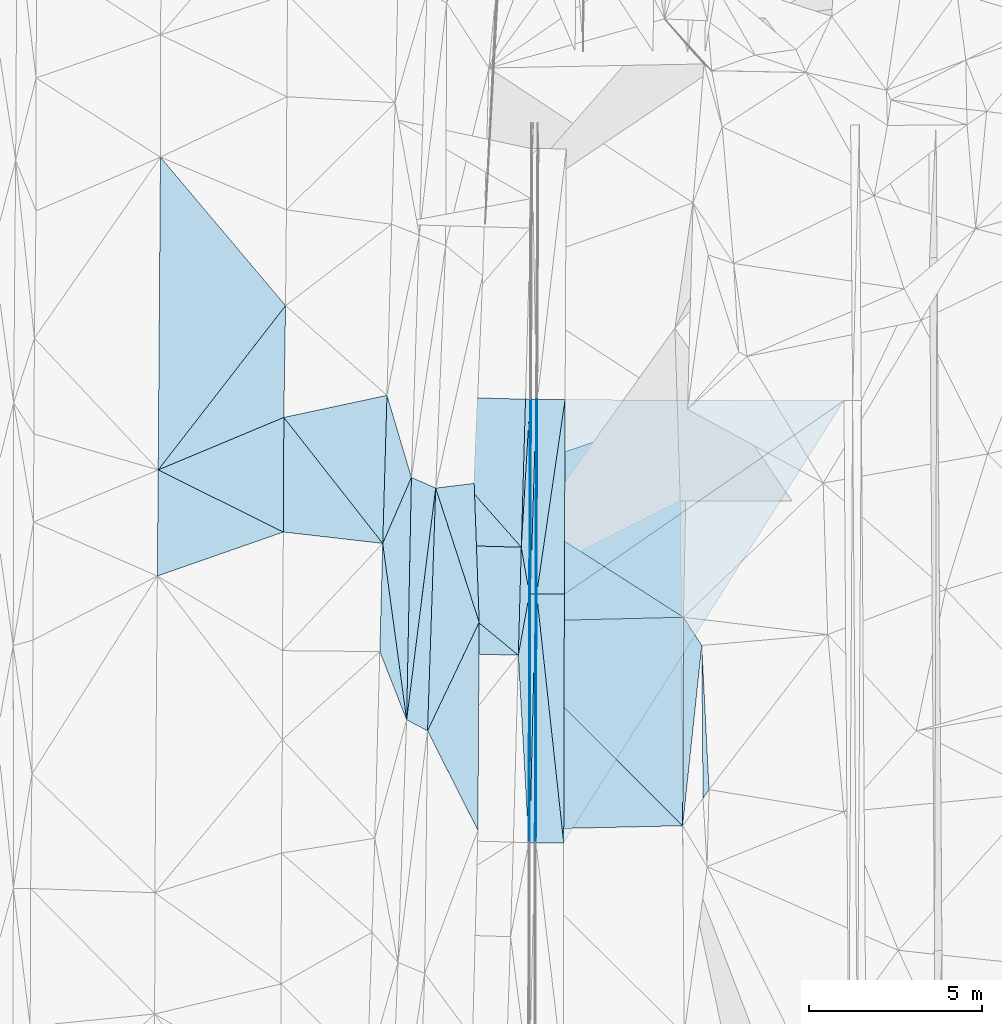
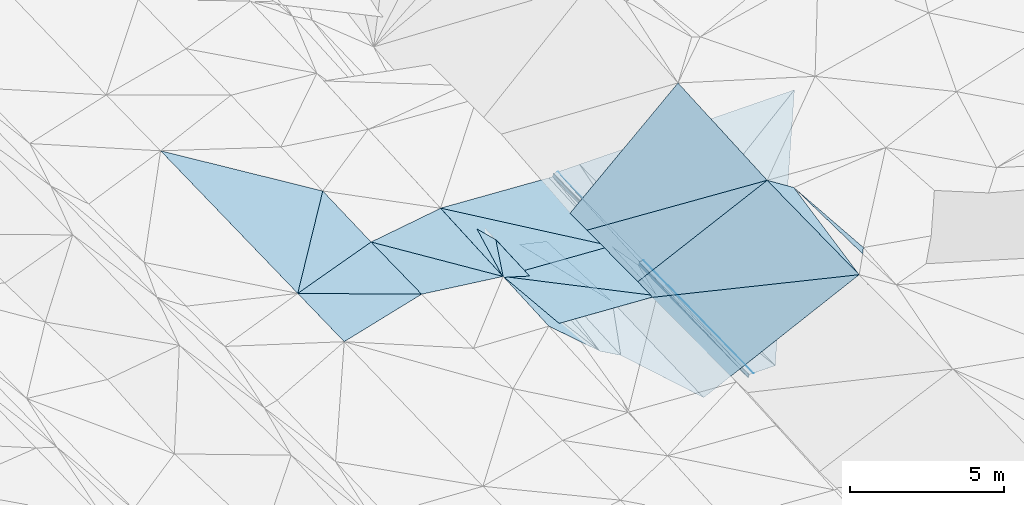
# One storey, part 146 of 275: 46 plates.
"""IFC2X3 building model written with IfcOpenShell, lengths in millimetres."""

from ifc_helpers import new_model, si_unit, frame, origin_with_axes, place, context, subcontext, project, spatial, polyline, outline, extrude, material, type_object, element, save


model = new_model("IFC2X3")

# Units and contexts
model_context = context("Model", 3, precision=1e-05, world=origin_with_axes())
body_context = subcontext(model_context, "Body", "Model", "MODEL_VIEW")
ifc_project = project(units=[si_unit("LENGTHUNIT", "METRE", prefix="MILLI"), si_unit("AREAUNIT", "SQUARE_METRE"), si_unit("VOLUMEUNIT", "CUBIC_METRE"), si_unit("MASSUNIT", "GRAM", prefix="KILO"), si_unit("TIMEUNIT", "SECOND"), si_unit("PLANEANGLEUNIT", "RADIAN"), si_unit("SOLIDANGLEUNIT", "STERADIAN"), si_unit("THERMODYNAMICTEMPERATUREUNIT", "DEGREE_CELSIUS"), si_unit("LUMINOUSINTENSITYUNIT", "LUMEN")], contexts=[model_context])

# Site, building, storey
site_placement = place(None, origin_with_axes())
site = spatial("IfcSite", under=ifc_project, at=site_placement, CompositionType="ELEMENT")
building_placement = place(site_placement, origin_with_axes())
building = spatial("IfcBuilding", under=site, at=building_placement, Name="Undefined", CompositionType="ELEMENT")
storey_placement = place(building_placement, origin_with_axes())
storey = spatial("IfcBuildingStorey", under=building, at=storey_placement, Name="Undefined", CompositionType="ELEMENT", Elevation=0.0)

# Plates
ifc_material = material()
plate_type_1 = type_object("IfcPlateType", PredefinedType="NOTDEFINED")
plate_1_placement = place(storey_placement, frame((-57823.9008921729, 104611.609112402, 43082.6182722905), z_axis=(0.0286392993893599, 0.0163561515630062, -0.999455985442348), x_axis=(0.0594025380463845, 0.9980711664855, 0.0180356620039886)))
element("IfcPlate", 1, at=plate_1_placement, inside=storey, type_object=plate_type_1, material=ifc_material, Name="00_PR", context=body_context, shape_type="SweptSolid", body=[
    extrude(outline(polyline([(0.0, 0.0), (4276.13916015625, -1.90993887372315e-08), (-1334.20239257813, 313.091430664063), (0.0, 0.0)])), frame((-8.85201319254618e-08, 2.18876761149539e-07, -0.5000001331573), z_axis=(0.0, 0.0, 1.0), x_axis=(1.0, 0.0, 0.0)), (0.0, 0.0, 1.0), 1.0),
])
plate_type_2 = type_object("IfcPlateType", PredefinedType="NOTDEFINED")
plate_2_placement = place(storey_placement, frame((-61700.3286359968, 108995.300084847, 43283.7523294641), z_axis=(-0.0315199465246086, 0.0179797566731114, -0.999341393779454), x_axis=(0.999095281886142, -0.0279929429634776, -0.0320158219805999)))
element("IfcPlate", 2, at=plate_2_placement, inside=storey, type_object=plate_type_2, material=ifc_material, Name="00_PR", context=body_context, shape_type="SweptSolid", body=[
    extrude(outline(polyline([(0.0, 0.0), (4002.05249023438, -6.22821971774101e-09), (4002.04248046875, 4274.02734375), (0.0, 0.0)])), frame((-8.85201319254618e-08, 2.18876761149539e-07, -0.5000001331573), z_axis=(0.0, 0.0, 1.0), x_axis=(1.0, 0.0, 0.0)), (0.0, 0.0, 1.0), 1.0),
])
plate_3_placement = place(storey_placement, frame((-57823.9308204421, 104611.610062335, 43082.6183267539), z_axis=(-0.031212602182097, 0.0182517517983424, -0.999346109724411), x_axis=(-0.999123977641245, 0.027314827964167, 0.0317045339915962)))
element("IfcPlate", 3, at=plate_3_placement, inside=storey, type_object=plate_type_2, material=ifc_material, Name="00_PR", context=body_context, shape_type="SweptSolid", body=[
    extrude(outline(polyline([(0.0, 0.0), (4002.01440429688, 6.28642737865448e-09), (3999.11840820313, 4276.76318359375), (0.0, 0.0)])), frame((-8.85201319254618e-08, 2.18876761149539e-07, -0.5000001331573), z_axis=(0.0, 0.0, 1.0), x_axis=(1.0, 0.0, 0.0)), (0.0, 0.0, 1.0), 1.0),
])
plate_type_3 = type_object("IfcPlateType", PredefinedType="NOTDEFINED")
plate_4_placement = place(storey_placement, frame((-61822.4393750529, 104720.924442803, 43209.500328325), z_axis=(-0.0312097734749768, 0.018353166415255, -0.999344340716539), x_axis=(0.999123977642084, -0.0273148279576798, -0.0317045339707643)))
element("IfcPlate", 4, at=plate_4_placement, inside=storey, type_object=plate_type_3, material=ifc_material, Name="00_PR", context=body_context, shape_type="SweptSolid", body=[
    extrude(outline(polyline([(0.0, 0.0), (4002.01440429688, 6.28642737865448e-09), (4003.7431640625, 3119.8994140625), (0.0, 0.0)])), frame((-8.85201319254618e-08, 2.18876761149539e-07, -0.5000001331573), z_axis=(0.0, 0.0, 1.0), x_axis=(1.0, 0.0, 0.0)), (0.0, 0.0, 1.0), 1.0),
])
plate_type_4 = type_object("IfcPlateType", PredefinedType="NOTDEFINED")
plate_5_placement = place(storey_placement, frame((-57909.1824641043, 101493.353414711, 43028.0133275653), z_axis=(-0.031046677135083, 0.0185509911334406, -0.999345768273843), x_axis=(-0.99914793329059, 0.0266263739699584, 0.0315347999891217)))
element("IfcPlate", 5, at=plate_5_placement, inside=storey, type_object=plate_type_4, material=ifc_material, Name="00_PR", context=body_context, shape_type="SweptSolid", body=[
    extrude(outline(polyline([(0.0, 0.0), (4001.99145507813, -5.77711034566164e-09), (4001.58422851563, 3122.66821289063), (0.0, 0.0)])), frame((-8.85201319254618e-08, 2.18876761149539e-07, -0.5000001331573), z_axis=(0.0, 0.0, 1.0), x_axis=(1.0, 0.0, 0.0)), (0.0, 0.0, 1.0), 1.0),
])
plate_type_5 = type_object("IfcPlateType", PredefinedType="NOTDEFINED")
plate_6_placement = place(storey_placement, frame((-57539.4264627461, 108877.337550422, 43280.0837362747), z_axis=(0.970144674503121, 0.000393049729116274, -0.242526608942491), x_axis=(-0.00371188600319583, -0.9998574751376, -0.0164697089762896)))
element("IfcPlate", 6, at=plate_6_placement, inside=storey, type_object=plate_type_5, material=ifc_material, Name="00_PR", context=body_context, shape_type="SweptSolid", body=[
    extrude(outline(polyline([(0.0, 0.0), (5616.76513671875, -1.08411768451333e-08), (5619.00341796875, 123.672706604004), (0.0, 0.0)])), frame((-8.85201319254618e-08, 2.18876761149539e-07, -0.5000001331573), z_axis=(0.0, 0.0, 1.0), x_axis=(1.0, 0.0, 0.0)), (0.0, 0.0, 1.0), 1.0),
])
plate_7_placement = place(storey_placement, frame((-57560.2765250611, 103261.373318993, 43187.5787186943), z_axis=(0.9701348129279, 0.00146785184983346, -0.242561930558561), x_axis=(-0.00264251999267643, -0.999858398584357, -0.0166192619695818)))
element("IfcPlate", 7, at=plate_7_placement, inside=storey, type_object=plate_type_5, material=ifc_material, Name="00_PR", context=body_context, shape_type="SweptSolid", body=[
    extrude(outline(polyline([(0.0, 0.0), (7180.59619140625, -1.12595444079489e-08), (7177.50830078125, 123.675369262695), (0.0, 0.0)])), frame((-8.85201319254618e-08, 2.18876761149539e-07, -0.5000001331573), z_axis=(0.0, 0.0, 1.0), x_axis=(1.0, 0.0, 0.0)), (0.0, 0.0, 1.0), 1.0),
])
plate_8_placement = place(storey_placement, frame((-57569.4166294153, 108879.492210397, 43160.1197385955), z_axis=(0.970145667403756, 0.000392890402904316, -0.242522637407009), x_axis=(0.242492487917739, -0.0174220049627916, 0.969996838678633)))
element("IfcPlate", 8, at=plate_8_placement, inside=storey, type_object=plate_type_5, material=ifc_material, Name="00_PR", context=body_context, shape_type="SweptSolid", body=[
    extrude(outline(polyline([(0.0, 0.0), (123.674629211426, 3.05590219795704e-10), (3.05898642539978, 5619.0703125), (0.0, 0.0)])), frame((-8.85201319254618e-08, 2.18876761149539e-07, -0.5000001331573), z_axis=(0.0, 0.0, 1.0), x_axis=(1.0, 0.0, 0.0)), (0.0, 0.0, 1.0), 1.0),
])
plate_9_placement = place(storey_placement, frame((-57590.2752770446, 103261.22264558, 43067.5787365894), z_axis=(0.970143388926868, 0.00146664967193269, -0.242527635250566), x_axis=(0.242525982975342, 0.00121810203125965, 0.970144145892396)))
element("IfcPlate", 9, at=plate_9_placement, inside=storey, type_object=plate_type_5, material=ifc_material, Name="00_PR", context=body_context, shape_type="SweptSolid", body=[
    extrude(outline(polyline([(0.0, 0.0), (123.69295501709, -7.27595761418343e-11), (-129.022125244141, 7174.1240234375), (0.0, 0.0)])), frame((-8.85201319254618e-08, 2.18876761149539e-07, -0.5000001331573), z_axis=(0.0, 0.0, 1.0), x_axis=(1.0, 0.0, 0.0)), (0.0, 0.0, 1.0), 1.0),
])
plate_type_6 = type_object("IfcPlateType", PredefinedType="NOTDEFINED")
plate_10_placement = place(storey_placement, frame((-57389.91242758, 108876.548700005, 43279.7050679046), z_axis=(8.74944481570353e-05, 0.0164692326707658, -0.999864369162117), x_axis=(-0.030408163980564, -0.999401956745784, -0.016464276966472)))
element("IfcPlate", 10, at=plate_10_placement, inside=storey, type_object=plate_type_6, material=ifc_material, Name="00_PR", context=body_context, shape_type="SweptSolid", body=[
    extrude(outline(polyline([(0.0, 0.0), (5618.52783203125, -8.65838956087828e-10), (3.76478433609009, 149.95393371582), (0.0, 0.0)])), frame((-8.85201319254618e-08, 2.18876761149539e-07, -0.5000001331573), z_axis=(0.0, 0.0, 1.0), x_axis=(1.0, 0.0, 0.0)), (0.0, 0.0, 1.0), 1.0),
])
plate_11_placement = place(storey_placement, frame((-57410.7617565643, 103260.646649343, 43187.2000696347), z_axis=(8.13458011182441e-05, 0.0166183795622564, -0.999861901886248), x_axis=(-0.0235278679924046, -0.999585093013532, -0.0166156929696005)))
element("IfcPlate", 11, at=plate_11_placement, inside=storey, type_object=plate_type_6, material=ifc_material, Name="00_PR", context=body_context, shape_type="SweptSolid", body=[
    extrude(outline(polyline([(0.0, 0.0), (7181.82470703125, 5.07789081893861e-08), (2.79523730278015, 149.975540161133), (0.0, 0.0)])), frame((-8.85201319254618e-08, 2.18876761149539e-07, -0.5000001331573), z_axis=(0.0, 0.0, 1.0), x_axis=(1.0, 0.0, 0.0)), (0.0, 0.0, 1.0), 1.0),
])
plate_12_placement = place(storey_placement, frame((-57560.7615532497, 103261.380817629, 43187.2000701747), z_axis=(8.06177093431787e-05, 0.0164694418593857, -0.999864366294562), x_axis=(0.0304081639715633, 0.99940195674603, 0.0164642769682023)))
element("IfcPlate", 12, at=plate_12_placement, inside=storey, type_object=plate_type_6, material=ifc_material, Name="00_PR", context=body_context, shape_type="SweptSolid", body=[
    extrude(outline(polyline([(0.0, 0.0), (5618.52783203125, -8.65838956087828e-10), (3.82741451263428, 149.952758789063), (0.0, 0.0)])), frame((-8.85201319254618e-08, 2.18876761149539e-07, -0.5000001331573), z_axis=(0.0, 0.0, 1.0), x_axis=(1.0, 0.0, 0.0)), (0.0, 0.0, 1.0), 1.0),
])
plate_13_placement = place(storey_placement, frame((-57579.7348068498, 96081.8015104293, 43067.8690714004), z_axis=(5.05940772002517e-05, 0.0166191032195452, -0.999861891887283), x_axis=(0.0235278679692896, 0.999585093014065, 0.0166156929702854)))
element("IfcPlate", 13, at=plate_13_placement, inside=storey, type_object=plate_type_6, material=ifc_material, Name="00_PR", context=body_context, shape_type="SweptSolid", body=[
    extrude(outline(polyline([(0.0, 0.0), (7181.82470703125, 5.07789081893861e-08), (3.07271218299866, 149.96875), (0.0, 0.0)])), frame((-8.85201319254618e-08, 2.18876761149539e-07, -0.5000001331573), z_axis=(0.0, 0.0, 1.0), x_axis=(1.0, 0.0, 0.0)), (0.0, 0.0, 1.0), 1.0),
])
plate_type_7 = type_object("IfcPlateType", PredefinedType="NOTDEFINED")
plate_14_placement = place(storey_placement, frame((-57359.9029055833, 108876.423056699, 43280.3051671508), z_axis=(0.0200622307838885, 0.0163920484379525, -0.999664347490687), x_axis=(-0.00371188600319583, -0.9998574751376, -0.0164697089762896)))
element("IfcPlate", 14, at=plate_14_placement, inside=storey, type_object=plate_type_7, material=ifc_material, Name="00_PR", context=body_context, shape_type="SweptSolid", body=[
    extrude(outline(polyline([(0.0, 0.0), (5616.6748046875, -1.7018464859575e-08), (-0.00435296120122075, 30.0057964324951), (0.0, 0.0)])), frame((-8.85201319254618e-08, 2.18876761149539e-07, -0.5000001331573), z_axis=(0.0, 0.0, 1.0), x_axis=(1.0, 0.0, 0.0)), (0.0, 0.0, 1.0), 1.0),
])
plate_15_placement = place(storey_placement, frame((-57380.7513738621, 103260.548735517, 43187.8001685812), z_axis=(0.0200470137815082, 0.0165630126239896, -0.999661834747762), x_axis=(-0.00264251999267643, -0.999858398584357, -0.0166192619695818)))
element("IfcPlate", 15, at=plate_15_placement, inside=storey, type_object=plate_type_7, material=ifc_material, Name="00_PR", context=body_context, shape_type="SweptSolid", body=[
    extrude(outline(polyline([(0.0, 0.0), (7180.28271484375, 1.65673554874957e-08), (-0.0086272107437253, 30.0065593719482), (0.0, 0.0)])), frame((-8.85201319254618e-08, 2.18876761149539e-07, -0.5000001331573), z_axis=(0.0, 0.0, 1.0), x_axis=(1.0, 0.0, 0.0)), (0.0, 0.0, 1.0), 1.0),
])
plate_16_placement = place(storey_placement, frame((-57410.751778097, 103260.646536081, 43187.2001698732), z_axis=(0.0200465116787781, 0.0163920272637285, -0.999664663180458), x_axis=(0.00371188599324788, 0.999857475137618, 0.016469708977407)))
element("IfcPlate", 16, at=plate_16_placement, inside=storey, type_object=plate_type_7, material=ifc_material, Name="00_PR", context=body_context, shape_type="SweptSolid", body=[
    extrude(outline(polyline([(0.0, 0.0), (5616.70263671875, -3.97922121919692e-08), (0.0233685877174139, 30.0065517425537), (0.0, 0.0)])), frame((-8.85201319254618e-08, 2.18876761149539e-07, -0.5000001331573), z_axis=(0.0, 0.0, 1.0), x_axis=(1.0, 0.0, 0.0)), (0.0, 0.0, 1.0), 1.0),
])
plate_17_placement = place(storey_placement, frame((-57429.7252913609, 96081.3448377906, 43067.8691710515), z_axis=(0.0200270951198568, 0.0165630718894112, -0.999662233012054), x_axis=(0.00264251997853649, 0.999858398584354, 0.0166192619720087)))
element("IfcPlate", 17, at=plate_17_placement, inside=storey, type_object=plate_type_7, material=ifc_material, Name="00_PR", context=body_context, shape_type="SweptSolid", body=[
    extrude(outline(polyline([(0.0, 0.0), (7180.318359375, 7.71251507103443e-09), (0.0272062122821808, 30.0059127807617), (0.0, 0.0)])), frame((-8.85201319254618e-08, 2.18876761149539e-07, -0.5000001331573), z_axis=(0.0, 0.0, 1.0), x_axis=(1.0, 0.0, 0.0)), (0.0, 0.0, 1.0), 1.0),
])
plate_type_8 = type_object("IfcPlateType", PredefinedType="NOTDEFINED")
plate_18_placement = place(storey_placement, frame((-57569.8858779446, 108879.50010041, 43159.7413161751), z_axis=(0.031644168475463, 0.0161757251763265, -0.99936829673375), x_axis=(-0.0594025380413828, -0.998071166485802, -0.0180356620037383)))
element("IfcPlate", 18, at=plate_18_placement, inside=storey, type_object=plate_type_8, material=ifc_material, Name="00_PR", context=body_context, shape_type="SweptSolid", body=[
    extrude(outline(polyline([(0.0, 0.0), (4276.13916015625, -1.90993887372315e-08), (4.15157032012939, 132.032211303711), (0.0, 0.0)])), frame((-8.85201319254618e-08, 2.18876761149539e-07, -0.5000001331573), z_axis=(0.0, 0.0, 1.0), x_axis=(1.0, 0.0, 0.0)), (0.0, 0.0, 1.0), 1.0),
])
plate_type_9 = type_object("IfcPlateType", PredefinedType="NOTDEFINED")
plate_19_placement = place(storey_placement, frame((-57590.7451207599, 103261.230245587, 43067.2003017855), z_axis=(0.0304511385856356, 0.0166683116903831, -0.999397266128055), x_axis=(-0.177212526972437, -0.983930915753807, -0.0218099359907035)))
element("IfcPlate", 19, at=plate_19_placement, inside=storey, type_object=plate_type_9, material=ifc_material, Name="00_PR", context=body_context, shape_type="SweptSolid", body=[
    extrude(outline(polyline([(0.0, 0.0), (1796.74987792969, -6.76664058119059e-09), (-1287.69799804688, 468.995025634766), (0.0, 0.0)])), frame((-8.85201319254618e-08, 2.18876761149539e-07, -0.5000001331573), z_axis=(0.0, 0.0, 1.0), x_axis=(1.0, 0.0, 0.0)), (0.0, 0.0, 1.0), 1.0),
])
plate_type_10 = type_object("IfcPlateType", PredefinedType="NOTDEFINED")
plate_20_placement = place(storey_placement, frame((-57909.1513230331, 101493.352406836, 43028.0133127853), z_axis=(0.0312267034950166, 0.0165281483901754, -0.999375661750689), x_axis=(0.177212526968748, 0.983930915754403, 0.0218099359937816)))
element("IfcPlate", 20, at=plate_20_placement, inside=storey, type_object=plate_type_10, material=ifc_material, Name="00_PR", context=body_context, shape_type="SweptSolid", body=[
    extrude(outline(polyline([(0.0, 0.0), (1796.74987792969, -6.76664058119059e-09), (-5268.19580078125, 1253.49353027344), (0.0, 0.0)])), frame((-8.85201319254618e-08, 2.18876761149539e-07, -0.5000001331573), z_axis=(0.0, 0.0, 1.0), x_axis=(1.0, 0.0, 0.0)), (0.0, 0.0, 1.0), 1.0),
])
plate_type_11 = type_object("IfcPlateType", PredefinedType="NOTDEFINED")
plate_21_placement = place(storey_placement, frame((-56559.9094753957, 108873.077554814, 43296.3051674812), z_axis=(0.0200465595605787, 0.0163943123081851, -0.999664624748583), x_axis=(-0.00371193902418557, -0.999857438666623, -0.0164719109911862)))
element("IfcPlate", 21, at=plate_21_placement, inside=storey, type_object=plate_type_11, material=ifc_material, Name="00_PR", context=body_context, shape_type="SweptSolid", body=[
    extrude(outline(polyline([(0.0, 0.0), (5615.923828125, 1.74331944435835e-08), (5616.56298828125, 800.159851074219), (0.0, 0.0)])), frame((-8.85201319254618e-08, 2.18876761149539e-07, -0.5000001331573), z_axis=(0.0, 0.0, 1.0), x_axis=(1.0, 0.0, 0.0)), (0.0, 0.0, 1.0), 1.0),
])
plate_22_placement = place(storey_placement, frame((-56580.7554528384, 103257.954424099, 43203.8001693149), z_axis=(0.0200470572782075, 0.0165652372355342, -0.999661797014278), x_axis=(-0.0026425120256765, -0.999858361619525, -0.0166214869886238)))
element("IfcPlate", 22, at=plate_22_placement, inside=storey, type_object=plate_type_11, material=ifc_material, Name="00_PR", context=body_context, shape_type="SweptSolid", body=[
    extrude(outline(polyline([(0.0, 0.0), (7179.32177734375, -2.27446435019374e-08), (-0.213999018073082, 800.160095214844), (0.0, 0.0)])), frame((-8.85201319254618e-08, 2.18876761149539e-07, -0.5000001331573), z_axis=(0.0, 0.0, 1.0), x_axis=(1.0, 0.0, 0.0)), (0.0, 0.0, 1.0), 1.0),
])
plate_23_placement = place(storey_placement, frame((-57380.7513665701, 103260.5486506, 43187.8001674589), z_axis=(0.0200622307838885, 0.0163920484379525, -0.999664347490687), x_axis=(0.00371188599324788, 0.999857475137618, 0.016469708977407)))
element("IfcPlate", 23, at=plate_23_placement, inside=storey, type_object=plate_type_11, material=ifc_material, Name="00_PR", context=body_context, shape_type="SweptSolid", body=[
    extrude(outline(polyline([(0.0, 0.0), (5616.6748046875, -1.7018464859575e-08), (5616.56298828125, 800.160400390625), (0.0, 0.0)])), frame((-8.85201319254618e-08, 2.18876761149539e-07, -0.5000001331573), z_axis=(0.0, 0.0, 1.0), x_axis=(1.0, 0.0, 0.0)), (0.0, 0.0, 1.0), 1.0),
])
plate_24_placement = place(storey_placement, frame((-57399.7254284312, 96081.2828046263, 43068.4691689635), z_axis=(0.0200270951198568, 0.0165630718894112, -0.999662233012054), x_axis=(0.00264251997853649, 0.999858398584354, 0.0166192619720087)))
element("IfcPlate", 24, at=plate_24_placement, inside=storey, type_object=plate_type_11, material=ifc_material, Name="00_PR", context=body_context, shape_type="SweptSolid", body=[
    extrude(outline(polyline([(0.0, 0.0), (7180.28271484375, 1.65673554874957e-08), (0.746965527534485, 800.159790039063), (0.0, 0.0)])), frame((-8.85201319254618e-08, 2.18876761149539e-07, -0.5000001331573), z_axis=(0.0, 0.0, 1.0), x_axis=(1.0, 0.0, 0.0)), (0.0, 0.0, 1.0), 1.0),
])
plate_type_12 = type_object("IfcPlateType", PredefinedType="NOTDEFINED")
plate_25_placement = place(storey_placement, frame((-56580.7554443777, 103257.954339471, 43203.800168191), z_axis=(0.0200619225218566, 0.0163942502081395, -0.999664317571073), x_axis=(0.00371193903121715, 0.999857438666677, 0.0164719109863101)))
element("IfcPlate", 25, at=plate_25_placement, inside=storey, type_object=plate_type_12, material=ifc_material, Name="00_PR", context=body_context, shape_type="SweptSolid", body=[
    extrude(outline(polyline([(0.0, 0.0), (5615.923828125, 1.74331944435835e-08), (5614.79833984375, 8049.54833984375), (0.0, 0.0)])), frame((-8.85201319254618e-08, 2.18876761149539e-07, -0.5000001331573), z_axis=(0.0, 0.0, 1.0), x_axis=(1.0, 0.0, 0.0)), (0.0, 0.0, 1.0), 1.0),
])
plate_type_13 = type_object("IfcPlateType", PredefinedType="NOTDEFINED")
plate_26_placement = place(storey_placement, frame((-56599.7269503277, 96079.6496068809, 43084.4691683066), z_axis=(0.0199434164080744, 0.0165655455214153, -0.999663864928383), x_axis=(0.00264251202433771, 0.99985836161956, 0.0166214869867599)))
element("IfcPlate", 26, at=plate_26_placement, inside=storey, type_object=plate_type_13, material=ifc_material, Name="00_PR", context=body_context, shape_type="SweptSolid", body=[
    extrude(outline(polyline([(0.0, 0.0), (7179.32177734375, -2.27446435019374e-08), (12785.5341796875, 8055.5302734375), (0.0, 0.0)])), frame((-8.85201319254618e-08, 2.18876761149539e-07, -0.5000001331573), z_axis=(0.0, 0.0, 1.0), x_axis=(1.0, 0.0, 0.0)), (0.0, 0.0, 1.0), 1.0),
])
plate_type_14 = type_object("IfcPlateType", PredefinedType="NOTDEFINED")
plate_27_placement = place(storey_placement, frame((-53025.5648986547, 108590.204056015, 45459.54451557), z_axis=(0.412045560642504, 0.0194406181262857, -0.910955826767507), x_axis=(-0.019872446457534, -0.999342808425213, -0.0303156250240719)))
element("IfcPlate", 27, at=plate_27_placement, inside=storey, type_object=plate_type_14, material=ifc_material, Name="00", context=body_context, shape_type="SweptSolid", body=[
    extrude(outline(polyline([(0.0, 0.0), (6003.5048828125, 2.32539605349302e-08), (2343.18090820313, 6708.90283203125), (0.0, 0.0)])), frame((-8.85201319254618e-08, 2.18876761149539e-07, -0.5000001331573), z_axis=(0.0, 0.0, 1.0), x_axis=(1.0, 0.0, 0.0)), (0.0, 0.0, 1.0), 1.0),
])
plate_type_15 = type_object("IfcPlateType", PredefinedType="NOTDEFINED")
plate_28_placement = place(storey_placement, frame((-61700.3260557459, 108995.299710518, 43279.5002384438), z_axis=(-0.0260910520145352, 0.0171140581762639, -0.999513064455645), x_axis=(0.285246195454412, -0.958157446592947, -0.023851949967803)))
element("IfcPlate", 28, at=plate_28_placement, inside=storey, type_object=plate_type_15, material=ifc_material, Name="00", context=body_context, shape_type="SweptSolid", body=[
    extrude(outline(polyline([(0.0, 0.0), (2473.59228515625, 6.12999428994954e-09), (4062.36303710938, 1336.90185546875), (0.0, 0.0)])), frame((-8.85201319254618e-08, 2.18876761149539e-07, -0.5000001331573), z_axis=(0.0, 0.0, 1.0), x_axis=(1.0, 0.0, 0.0)), (0.0, 0.0, 1.0), 1.0),
])
plate_type_16 = type_object("IfcPlateType", PredefinedType="NOTDEFINED")
plate_29_placement = place(storey_placement, frame((-59183.9356192571, 106453.804543989, 42628.5225461314), z_axis=(-0.296856989701602, -0.00643981507828023, -0.954900233766366), x_axis=(0.0361168685035097, -0.999337493476646, -0.00448842303212533)))
element("IfcPlate", 29, at=plate_29_placement, inside=storey, type_object=plate_type_16, material=ifc_material, Name="00", context=body_context, shape_type="SweptSolid", body=[
    extrude(outline(polyline([(0.0, 0.0), (4010.31713867188, 1.13141140900552e-08), (93.6664047241211, 1166.81945800781), (0.0, 0.0)])), frame((-8.85201319254618e-08, 2.18876761149539e-07, -0.5000001331573), z_axis=(0.0, 0.0, 1.0), x_axis=(1.0, 0.0, 0.0)), (0.0, 0.0, 1.0), 1.0),
])
plate_type_17 = type_object("IfcPlateType", PredefinedType="NOTDEFINED")
plate_30_placement = place(storey_placement, frame((-53166.7067379056, 96573.020962282, 45189.5010538502), z_axis=(0.063550162685878, 0.0143638686401572, -0.997875270813085), x_axis=(0.00359956936395501, 0.999886612786464, 0.0146220610997866)))
element("IfcPlate", 30, at=plate_30_placement, inside=storey, type_object=plate_type_17, material=ifc_material, Name="00", context=body_context, shape_type="SweptSolid", body=[
    extrude(outline(polyline([(0.0, 0.0), (6018.3037109375, -3.35785443894565e-08), (5206.1884765625, 533.534790039063), (0.0, 0.0)])), frame((-8.85201319254618e-08, 2.18876761149539e-07, -0.5000001331573), z_axis=(0.0, 0.0, 1.0), x_axis=(1.0, 0.0, 0.0)), (0.0, 0.0, 1.0), 1.0),
])
plate_type_18 = type_object("IfcPlateType", PredefinedType="NOTDEFINED")
plate_31_placement = place(storey_placement, frame((-60529.4749017875, 99312.9770933439, 42907.5202353705), z_axis=(-0.28105310192529, 0.0186250859934511, -0.959511469483252), x_axis=(-0.853873442808884, 0.451534949259039, 0.258875130638965)))
element("IfcPlate", 31, at=plate_31_placement, inside=storey, type_object=plate_type_18, material=ifc_material, Name="00", context=body_context, shape_type="SweptSolid", body=[
    extrude(outline(polyline([(0.0, 0.0), (706.904541015625, -2.67027644440532e-09), (2979.45336914063, 6344.99755859375), (0.0, 0.0)])), frame((-8.85201319254618e-08, 2.18876761149539e-07, -0.5000001331573), z_axis=(0.0, 0.0, 1.0), x_axis=(1.0, 0.0, 0.0)), (0.0, 0.0, 1.0), 1.0),
])
plate_type_19 = type_object("IfcPlateType", PredefinedType="NOTDEFINED")
plate_32_placement = place(storey_placement, frame((-52578.4007683072, 97364.4373291946, 45329.5135893271), z_axis=(0.231578444969011, -0.00467138331009331, -0.972805017464294), x_axis=(-0.0083927666252757, 0.999941661685069, -0.00679960990617994)))
element("IfcPlate", 32, at=plate_32_placement, inside=storey, type_object=plate_type_19, material=ifc_material, Name="00", context=body_context, shape_type="SweptSolid", body=[
    extrude(outline(polyline([(0.0, 0.0), (4412.017578125, 1.6858393792063e-08), (249.727020263672, 180.101135253906), (0.0, 0.0)])), frame((-8.85201319254618e-08, 2.18876761149539e-07, -0.5000001331573), z_axis=(0.0, 0.0, 1.0), x_axis=(1.0, 0.0, 0.0)), (0.0, 0.0, 1.0), 1.0),
])
plate_type_20 = type_object("IfcPlateType", PredefinedType="NOTDEFINED")
plate_33_placement = place(storey_placement, frame((-59039.0701557281, 102446.160050375, 42610.5155342119), z_axis=(-0.246106780887081, 0.0252225602404607, -0.968914482736384), x_axis=(-0.00612032544539384, -0.999681856397625, -0.0244689110064504)))
element("IfcPlate", 33, at=plate_33_placement, inside=storey, type_object=plate_type_20, material=ifc_material, Name="00", context=body_context, shape_type="SweptSolid", body=[
    extrude(outline(polyline([(0.0, 0.0), (6007.623046875, -1.03900674730539e-08), (3134.03735351563, 1517.92248535156), (0.0, 0.0)])), frame((-8.85201319254618e-08, 2.18876761149539e-07, -0.5000001331573), z_axis=(0.0, 0.0, 1.0), x_axis=(1.0, 0.0, 0.0)), (0.0, 0.0, 1.0), 1.0),
])
plate_type_21 = type_object("IfcPlateType", PredefinedType="NOTDEFINED")
plate_34_placement = place(storey_placement, frame((-60994.7456433165, 106625.209839948, 43220.5003236999), z_axis=(-0.030864054939222, 0.0191876311119419, -0.999339404269151), x_axis=(-0.0197568294345855, -0.999632100887461, -0.0185830720284383)))
element("IfcPlate", 34, at=plate_34_placement, inside=storey, type_object=plate_type_21, material=ifc_material, Name="00", context=body_context, shape_type="SweptSolid", body=[
    extrude(outline(polyline([(0.0, 0.0), (6995.6142578125, -3.96394170820713e-08), (1920.14135742188, 790.288635253906), (0.0, 0.0)])), frame((-8.85201319254618e-08, 2.18876761149539e-07, -0.5000001331573), z_axis=(0.0, 0.0, 1.0), x_axis=(1.0, 0.0, 0.0)), (0.0, 0.0, 1.0), 1.0),
])
plate_type_22 = type_object("IfcPlateType", PredefinedType="NOTDEFINED")
plate_35_placement = place(storey_placement, frame((-61133.1022236078, 99632.1718440931, 43090.526730574), z_axis=(-0.321724660888628, 0.023954511048169, -0.946530202358351), x_axis=(0.0197568294688124, 0.999632100886466, 0.0185830720455362)))
element("IfcPlate", 35, at=plate_35_placement, inside=storey, type_object=plate_type_22, material=ifc_material, Name="00", context=body_context, shape_type="SweptSolid", body=[
    extrude(outline(polyline([(0.0, 0.0), (6995.6142578125, -3.96394170820713e-08), (6698.21044921875, 746.627075195313), (0.0, 0.0)])), frame((-8.85201319254618e-08, 2.18876761149539e-07, -0.5000001331573), z_axis=(0.0, 0.0, 1.0), x_axis=(1.0, 0.0, 0.0)), (0.0, 0.0, 1.0), 1.0),
])
plate_type_23 = type_object("IfcPlateType", PredefinedType="NOTDEFINED")
plate_36_placement = place(storey_placement, frame((-61822.440286182, 104720.924434239, 43209.500344702), z_axis=(-0.0327546961944724, 0.0182598963439423, -0.999296605649552), x_axis=(-0.99290677477539, 0.113742429380654, 0.0346236387995238)))
element("IfcPlate", 36, at=plate_36_placement, inside=storey, type_object=plate_type_23, material=ifc_material, Name="00", context=body_context, shape_type="SweptSolid", body=[
    extrude(outline(polyline([(0.0, 0.0), (2888.2001953125, -6.46105036139488e-09), (3253.02954101563, 3288.37329101563), (0.0, 0.0)])), frame((-8.85201319254618e-08, 2.18876761149539e-07, -0.5000001331573), z_axis=(0.0, 0.0, 1.0), x_axis=(1.0, 0.0, 0.0)), (0.0, 0.0, 1.0), 1.0),
])
plate_type_24 = type_object("IfcPlateType", PredefinedType="NOTDEFINED")
plate_37_placement = place(storey_placement, frame((-64626.5664942844, 111583.074622571, 43419.5006345692), z_axis=(-0.0480881098278874, 0.0162260082001129, -0.998711294794983), x_axis=(-0.0154947763387013, -0.99975984910787, -0.015496968026792)))
element("IfcPlate", 37, at=plate_37_placement, inside=storey, type_object=plate_type_24, material=ifc_material, Name="00", context=body_context, shape_type="SweptSolid", body=[
    extrude(outline(polyline([(0.0, 0.0), (3226.43774414063, 4.83123585581779e-09), (4795.8466796875, 3607.04248046875), (0.0, 0.0)])), frame((-8.85201319254618e-08, 2.18876761149539e-07, -0.5000001331573), z_axis=(0.0, 0.0, 1.0), x_axis=(1.0, 0.0, 0.0)), (0.0, 0.0, 1.0), 1.0),
])
plate_type_25 = type_object("IfcPlateType", PredefinedType="NOTDEFINED")
plate_38_placement = place(storey_placement, frame((-64690.1618646925, 105049.435359116, 43309.5006735094), z_axis=(-0.048957804539737, 0.0183144831801427, -0.99863292208924), x_axis=(-0.894648728465606, 0.443734011475979, 0.051997881825227)))
element("IfcPlate", 38, at=plate_38_placement, inside=storey, type_object=plate_type_25, material=ifc_material, Name="00", context=body_context, shape_type="SweptSolid", body=[
    extrude(outline(polyline([(0.0, 0.0), (4038.6259765625, -6.70115696266294e-09), (1458.81298828125, 2969.5732421875), (0.0, 0.0)])), frame((-8.85201319254618e-08, 2.18876761149539e-07, -0.5000001331573), z_axis=(0.0, 0.0, 1.0), x_axis=(1.0, 0.0, 0.0)), (0.0, 0.0, 1.0), 1.0),
])
plate_type_26 = type_object("IfcPlateType", PredefinedType="NOTDEFINED")
plate_39_placement = place(storey_placement, frame((-59039.0619518881, 102446.155946336, 42610.5134420598), z_axis=(-0.229718287355059, 0.0170293727215166, -0.973108169177184), x_axis=(-0.427991725508005, -0.899749343142231, 0.0852889348731949)))
element("IfcPlate", 39, at=plate_39_placement, inside=storey, type_object=plate_type_26, material=ifc_material, Name="00", context=body_context, shape_type="SweptSolid", body=[
    extrude(outline(polyline([(0.0, 0.0), (3482.28051757813, 1.25146470963955e-08), (-2915.939453125, 2863.37548828125), (0.0, 0.0)])), frame((-8.85201319254618e-08, 2.18876761149539e-07, -0.5000001331573), z_axis=(0.0, 0.0, 1.0), x_axis=(1.0, 0.0, 0.0)), (0.0, 0.0, 1.0), 1.0),
])
plate_type_27 = type_object("IfcPlateType", PredefinedType="NOTDEFINED")
plate_40_placement = place(storey_placement, frame((-68303.3142314519, 106841.510949764, 43519.5007078551), z_axis=(-0.0504547028674782, 0.0180642605565002, -0.998562970197224), x_axis=(0.00724829532926695, 0.999816702633005, 0.0177207040177693)))
element("IfcPlate", 40, at=plate_40_placement, inside=storey, type_object=plate_type_27, material=ifc_material, Name="00", context=body_context, shape_type="SweptSolid", body=[
    extrude(outline(polyline([(0.0, 0.0), (9028.986328125, 5.28234522789717e-09), (4765.57373046875, 3646.94506835938), (0.0, 0.0)])), frame((-8.85201319254618e-08, 2.18876761149539e-07, -0.5000001331573), z_axis=(0.0, 0.0, 1.0), x_axis=(1.0, 0.0, 0.0)), (0.0, 0.0, 1.0), 1.0),
])
plate_type_28 = type_object("IfcPlateType", PredefinedType="NOTDEFINED")
plate_41_placement = place(storey_placement, frame((-68327.600270759, 103780.283365377, 43469.5006782267), z_axis=(-0.0497551669884212, 0.0167055431967251, -0.998621724270235), x_axis=(0.00793223933104697, 0.999835181501103, 0.0163306280299292)))
element("IfcPlate", 41, at=plate_41_placement, inside=storey, type_object=plate_type_28, material=ifc_material, Name="00", context=body_context, shape_type="SweptSolid", body=[
    extrude(outline(polyline([(0.0, 0.0), (3061.7314453125, 2.1580490283668e-08), (1295.18212890625, 3631.77685546875), (0.0, 0.0)])), frame((-8.85201319254618e-08, 2.18876761149539e-07, -0.5000001331573), z_axis=(0.0, 0.0, 1.0), x_axis=(1.0, 0.0, 0.0)), (0.0, 0.0, 1.0), 1.0),
])
plate_type_29 = type_object("IfcPlateType", PredefinedType="NOTDEFINED")
plate_42_placement = place(storey_placement, frame((-64676.5523452852, 108357.412346366, 43369.5003545179), z_axis=(-0.0339329107074498, 0.0173341660531909, -0.999273778430196), x_axis=(0.977366811793856, 0.2094769726226, -0.0295552557895213)))
element("IfcPlate", 42, at=plate_42_placement, inside=storey, type_object=plate_type_29, material=ifc_material, Name="00", context=body_context, shape_type="SweptSolid", body=[
    extrude(outline(polyline([(0.0, 0.0), (3045.1435546875, -5.73345459997654e-09), (2032.48205566406, 4155.0712890625), (0.0, 0.0)])), frame((-8.85201319254618e-08, 2.18876761149539e-07, -0.5000001331573), z_axis=(0.0, 0.0, 1.0), x_axis=(1.0, 0.0, 0.0)), (0.0, 0.0, 1.0), 1.0),
])
plate_type_30 = type_object("IfcPlateType", PredefinedType="NOTDEFINED")
plate_43_placement = place(storey_placement, frame((-61822.4464955237, 104720.923921698, 43209.5005766503), z_axis=(-0.0451749080990828, 0.0172367299604628, -0.998830377400743), x_axis=(0.134228549610871, -0.990679559490201, -0.023166935007968)))
element("IfcPlate", 43, at=plate_43_placement, inside=storey, type_object=plate_type_30, material=ifc_material, Name="00", context=body_context, shape_type="SweptSolid", body=[
    extrude(outline(polyline([(0.0, 0.0), (5136.630859375, -1.86992110684514e-08), (3081.62866210938, 504.047943115234), (0.0, 0.0)])), frame((-8.85201319254618e-08, 2.18876761149539e-07, -0.5000001331573), z_axis=(0.0, 0.0, 1.0), x_axis=(1.0, 0.0, 0.0)), (0.0, 0.0, 1.0), 1.0),
])
plate_type_31 = type_object("IfcPlateType", PredefinedType="NOTDEFINED")
plate_44_placement = place(storey_placement, frame((-59038.7412009817, 102446.156926604, 42610.5444538243), z_axis=(0.4118004868444, 0.0189748115237118, -0.911076459778407), x_axis=(-0.0361168685383462, 0.999337493475516, 0.00448842300336125)))
element("IfcPlate", 44, at=plate_44_placement, inside=storey, type_object=plate_type_31, material=ifc_material, Name="00", context=body_context, shape_type="SweptSolid", body=[
    extrude(outline(polyline([(0.0, 0.0), (4010.31713867188, 1.13141140900552e-08), (-56.5057563781738, 6470.57177734375), (0.0, 0.0)])), frame((-8.85201319254618e-08, 2.18876761149539e-07, -0.5000001331573), z_axis=(0.0, 0.0, 1.0), x_axis=(1.0, 0.0, 0.0)), (0.0, 0.0, 1.0), 1.0),
])
plate_type_32 = type_object("IfcPlateType", PredefinedType="NOTDEFINED")
plate_45_placement = place(storey_placement, frame((-59075.5064788001, 96440.4453183674, 42463.5459802011), z_axis=(0.418458797120715, 0.0196634832820188, -0.908022897584363), x_axis=(0.00612032541228436, 0.999681856397617, 0.0244689110150548)))
element("IfcPlate", 45, at=plate_45_placement, inside=storey, type_object=plate_type_32, material=ifc_material, Name="00", context=body_context, shape_type="SweptSolid", body=[
    extrude(outline(polyline([(0.0, 0.0), (6007.623046875, -1.03900674730539e-08), (235.403244018555, 6504.55615234375), (0.0, 0.0)])), frame((-8.85201319254618e-08, 2.18876761149539e-07, -0.5000001331573), z_axis=(0.0, 0.0, 1.0), x_axis=(1.0, 0.0, 0.0)), (0.0, 0.0, 1.0), 1.0),
])
plate_type_33 = type_object("IfcPlateType", PredefinedType="NOTDEFINED")
plate_46_placement = place(storey_placement, frame((-53144.8692566161, 102590.640899176, 45277.5444378106), z_axis=(0.411990999162812, 0.0118406726828273, -0.911110978464889), x_axis=(-0.00359956942396714, -0.999886612787697, -0.0146220610006726)))
element("IfcPlate", 46, at=plate_46_placement, inside=storey, type_object=plate_type_33, material=ifc_material, Name="00", context=body_context, shape_type="SweptSolid", body=[
    extrude(outline(polyline([(0.0, 0.0), (6018.3037109375, -3.35785443894565e-08), (204.68359375, 6467.58056640625), (0.0, 0.0)])), frame((-8.85201319254618e-08, 2.18876761149539e-07, -0.5000001331573), z_axis=(0.0, 0.0, 1.0), x_axis=(1.0, 0.0, 0.0)), (0.0, 0.0, 1.0), 1.0),
])

save(model, "model.ifc")
